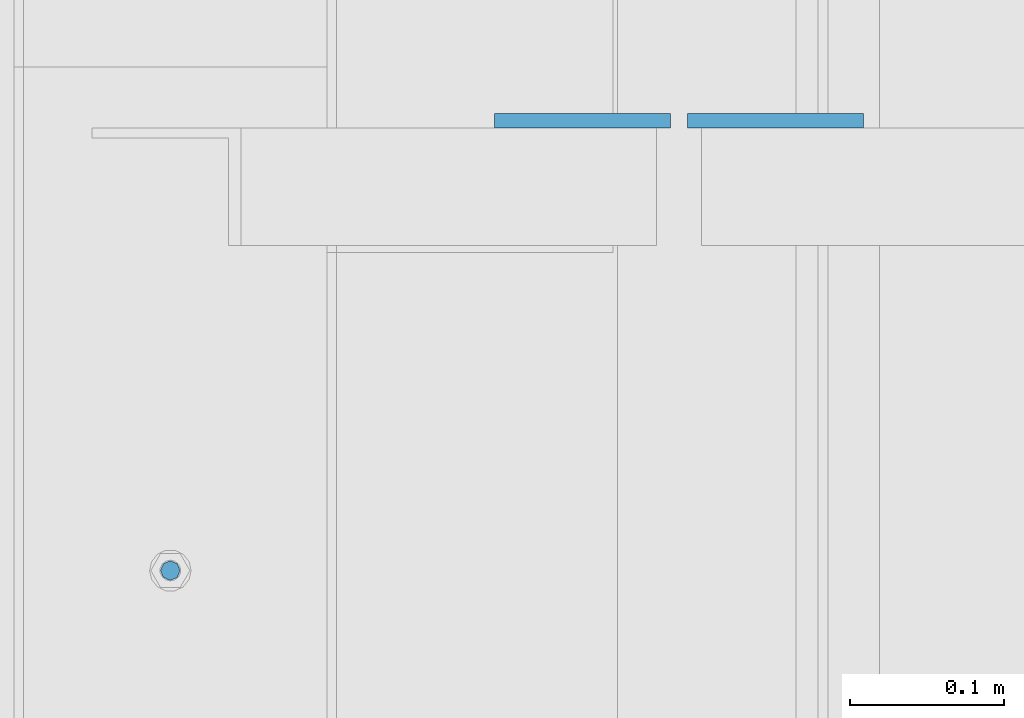
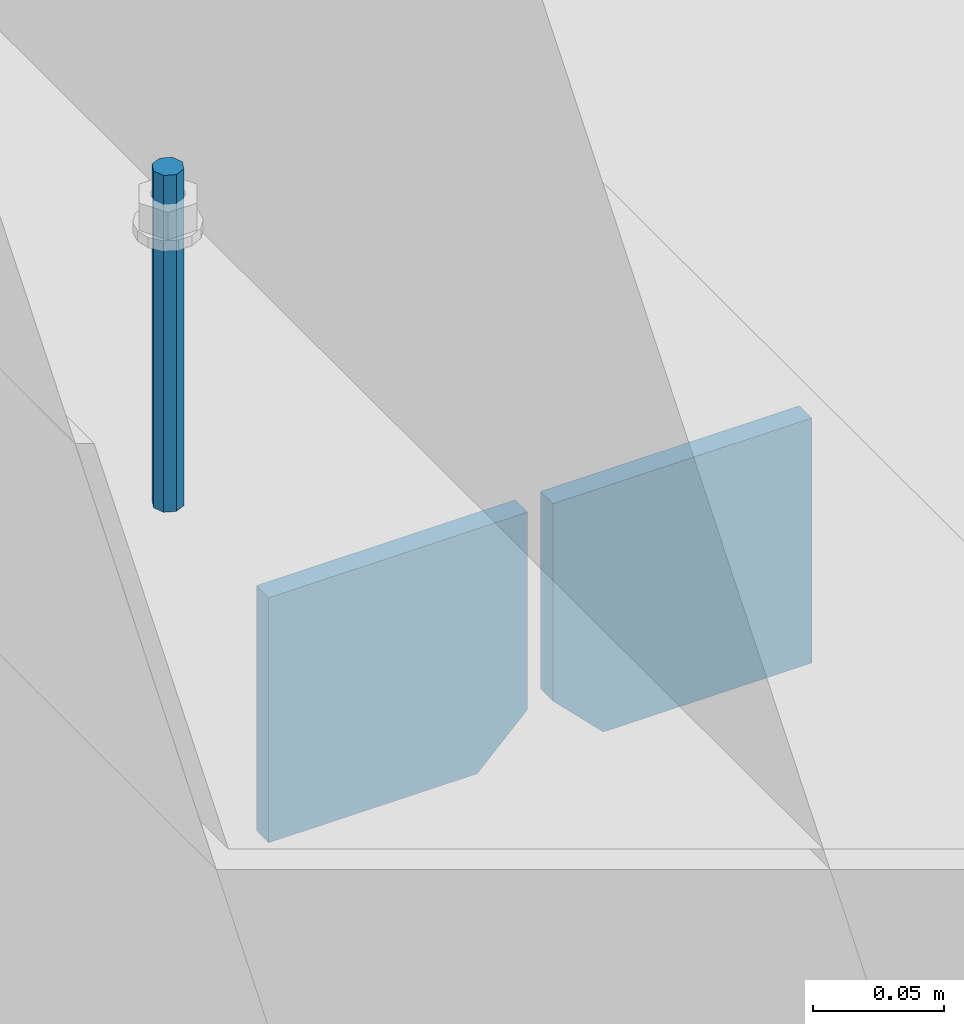
# One storey, part 503 of 1179: 3 columns, 1 element without a shape of its own.
"""IFC2X3 building model written with IfcOpenShell, lengths in millimetres."""

from ifc_helpers import new_model, si_unit, frame, origin_with_axes, place, context, subcontext, project, spatial, faceted_brep, material, type_object, element, aggregate, save


model = new_model("IFC2X3")

# Units and contexts
model_context = context("Model", 3, precision=1e-05, world=origin_with_axes())
body_context = subcontext(model_context, "Body", "Model", "MODEL_VIEW")
ifc_project = project(units=[si_unit("LENGTHUNIT", "METRE", prefix="MILLI"), si_unit("AREAUNIT", "SQUARE_METRE"), si_unit("VOLUMEUNIT", "CUBIC_METRE"), si_unit("MASSUNIT", "GRAM", prefix="KILO"), si_unit("TIMEUNIT", "SECOND"), si_unit("PLANEANGLEUNIT", "RADIAN"), si_unit("SOLIDANGLEUNIT", "STERADIAN"), si_unit("THERMODYNAMICTEMPERATUREUNIT", "DEGREE_CELSIUS"), si_unit("LUMINOUSINTENSITYUNIT", "LUMEN")], contexts=[model_context])

# Site, building, storey
site_placement = place(None, origin_with_axes())
site = spatial("IfcSite", under=ifc_project, at=site_placement, CompositionType="ELEMENT")
building_placement = place(site_placement, origin_with_axes())
building = spatial("IfcBuilding", under=site, at=building_placement, Name="Undefined", CompositionType="ELEMENT")
storey_placement = place(building_placement, origin_with_axes())
storey = spatial("IfcBuildingStorey", under=building, at=storey_placement, Name="Undefined", CompositionType="ELEMENT", Elevation=0.0)

# Assembly, columns
assembly_placement = place(storey_placement, origin_with_axes())
assembly = element("IfcElementAssembly", 1, at=assembly_placement, inside=storey, Name="BEAM", AssemblyPlace="NOTDEFINED", PredefinedType="RIGID_FRAME")
ifc_material_1 = material(Name="STEEL/A36")
column_type_1 = type_object("IfcColumnType", PredefinedType="NOTDEFINED")
column_1_placement = place(assembly_placement, frame((494.506249999995, 40579.675, 3702.05), z_axis=(-1.0, 0.0, 0.0), x_axis=(0.0, 0.0, 1.0)))
column_1 = element("IfcColumn", 2, at=column_1_placement, type_object=column_type_1, material=ifc_material_1, Name="PLATE", context=body_context, shape_type="Brep", body=[
    faceted_brep([(22.2250000000004, 4.76250000000073, 57.1500000000015), (0.0, 4.76250000000073, 34.9249999999993), (0.0, -4.76250000000073, 34.9249999999993), (22.2250000000004, -4.76250000000073, 57.1500000000015), (114.300000000001, 4.76250000000073, 57.1500000000015), (114.300000000001, 4.76250000000073, -57.1500000000015), (0.0, 4.76250000000073, -57.1500000000015), (114.300000000001, -4.76250000000073, 57.1500000000015), (0.0, -4.76250000000073, -57.1500000000015), (114.300000000001, -4.76250000000073, -57.1500000000015)], [[[0, 1, 2, 3]], [[4, 5, 6, 1, 0]], [[7, 4, 0, 3]], [[8, 9, 7, 3, 2]], [[8, 6, 5, 9]], [[7, 9, 5, 4]], [[6, 8, 2, 1]]]),
])
column_2_placement = place(assembly_placement, frame((369.09375, 40579.675, 3702.05), z_axis=(1.0, 0.0, 0.0), x_axis=(0.0, 0.0, 1.0)))
column_2 = element("IfcColumn", 3, at=column_2_placement, type_object=column_type_1, material=ifc_material_1, Name="PLATE", context=body_context, shape_type="Brep", body=[
    faceted_brep([(22.2250000000004, 4.76250000000073, 57.1500000000015), (0.0, 4.76250000000073, 34.9249999999993), (0.0, -4.76250000000073, 34.9249999999993), (22.2250000000004, -4.76250000000073, 57.1500000000015), (114.300000000001, 4.76250000000073, 57.1500000000015), (114.300000000001, 4.76250000000073, -57.1500000000015), (0.0, 4.76250000000073, -57.1500000000015), (114.300000000001, -4.76250000000073, 57.1500000000015), (0.0, -4.76250000000073, -57.1500000000015), (114.300000000001, -4.76250000000073, -57.1500000000015)], [[[0, 1, 2, 3]], [[4, 5, 6, 1, 0]], [[7, 4, 0, 3]], [[8, 9, 7, 3, 2]], [[8, 6, 5, 9]], [[7, 9, 5, 4]], [[6, 8, 2, 1]]]),
])
ifc_material_2 = material(Name="STEEL/A307")
column_type_2 = type_object("IfcColumnType", PredefinedType="NOTDEFINED")
column_3_placement = place(assembly_placement, frame((101.600000006011, 40287.5749988592, 4108.45), z_axis=(0.0, 1.0, 0.0), x_axis=(0.0, 0.0, 1.0)))
column_3 = element("IfcColumn", 4, at=column_3_placement, type_object=column_type_2, material=ifc_material_2, Name="THREADED ROD", context=body_context, shape_type="Brep", body=[
    faceted_brep([(0.0, -6.34999999999854, 0.0), (0.0, -4.49012806053361, -4.49012806053452), (157.162499999999, -4.49012806053361, -4.49012806053361), (157.162499999999, -6.34999999999854, 0.0), (0.0, 0.0, -6.34999999999991), (157.162499999999, 0.0, -6.34999999999854), (0.0, 4.49012806053361, -4.49012806053452), (157.162499999999, 4.49012806053361, -4.49012806053361), (0.0, 6.34999999999854, 0.0), (157.162499999999, 6.34999999999854, 0.0), (0.0, 4.49012806053361, 4.49012806053452), (157.162499999999, 4.49012806053361, 4.49012806053361), (0.0, 0.0, 6.34999999999991), (157.162499999999, 0.0, 6.34999999999854), (0.0, -4.49012806053361, 4.49012806053452), (157.162499999999, -4.49012806053361, 4.49012806053361)], [[[0, 1, 2, 3]], [[1, 4, 5, 2]], [[4, 6, 7, 5]], [[6, 8, 9, 7]], [[8, 10, 11, 9]], [[10, 12, 13, 11]], [[12, 14, 15, 13]], [[14, 0, 3, 15]], [[5, 7, 9, 11, 13, 15, 3, 2]], [[14, 12, 10, 8, 6, 4, 1, 0]]]),
])
aggregate(assembly, [column_1, column_2, column_3])

save(model, "model.ifc")
